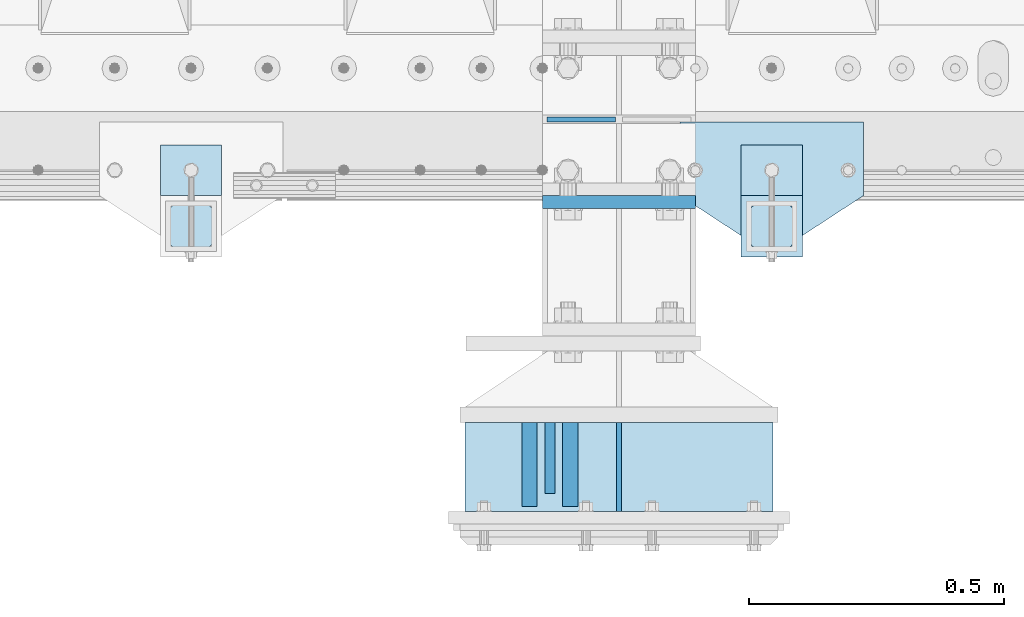
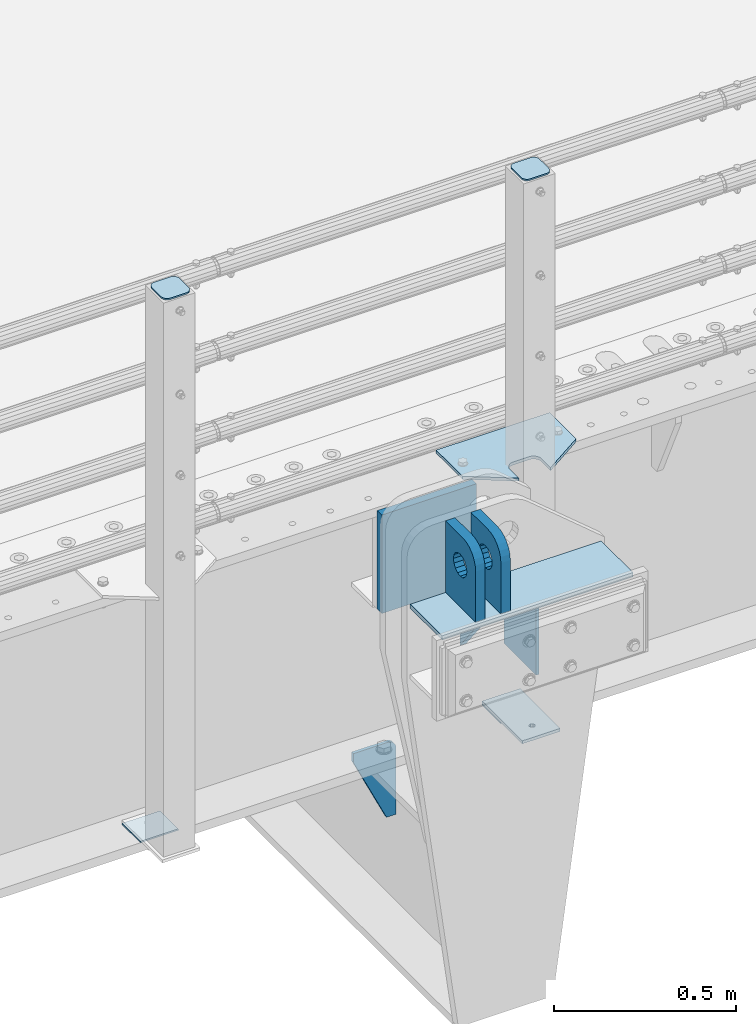
# One storey, part 198 of 240: 13 plates.
"""IFC2X3 building model written with IfcOpenShell, lengths in millimetres."""

import ifcopenshell
import ifcopenshell.guid

model = None  # the IFC model being written
_history = None  # IfcOwnerHistory: only IFC2X3 demands one
_inside = {}  # id of a spatial element -> (the spatial element, [elements in it])
_under = {}  # id of a project, library or spatial element -> (it, [spatial elements below it])
_declared = {}  # id of a project -> (the project, [libraries it declares])
_typed = {}  # id of a type object -> (the type object, [elements of that type])
_made_of = {}  # id of a material, layer set ... -> (it, [elements and type objects made of it])


def new_model(schema):
    """Start an empty IFC model of exactly this schema.

    Asked for "IFC4X3", IfcOpenShell would pick the latest addendum, in which some entities
    have other attributes; the version numbers below select the first issue.
    IFC2X3 requires an IfcOwnerHistory on every rooted entity: one is made here for all.
    """
    global model, _history
    if schema == "IFC4X3":
        model = ifcopenshell.file(schema_version=(4, 3, 0, 0))
    else:
        model = ifcopenshell.file(schema=schema)
    _inside.clear()
    _under.clear()
    _declared.clear()
    _typed.clear()
    _made_of.clear()
    _history = None
    if model.schema == "IFC2X3":
        org = make("IfcOrganization", Name="unknown")
        user = make(
            "IfcPersonAndOrganization",
            ThePerson=make("IfcPerson", FamilyName="unknown"),
            TheOrganization=org,
        )
        app = make(
            "IfcApplication",
            ApplicationDeveloper=org,
            Version="unknown",
            ApplicationFullName="unknown",
            ApplicationIdentifier="unknown",
        )
        _history = make(
            "IfcOwnerHistory",
            OwningUser=user,
            OwningApplication=app,
            ChangeAction="ADDED",
            CreationDate=0,
        )
    return model


def make(cls, **values):
    """One entity of the class cls with the attributes given. An attribute that is None is left unset."""
    return model.create_entity(
        cls, **{name: value for name, value in values.items() if value is not None}
    )


def rooted(cls, **values):
    """An entity with a GlobalId (a new one), such as an element, a storey or a relation."""
    return make(cls, GlobalId=ifcopenshell.guid.new(), OwnerHistory=_history, **values)


def si_unit(unit_type, name, prefix=None):
    """IfcSIUnit, for example si_unit("LENGTHUNIT", "METRE", prefix="MILLI")."""
    return make("IfcSIUnit", UnitType=unit_type, Prefix=prefix, Name=name)


def assignment(units):
    """IfcUnitAssignment: the units of a project."""
    return None if units is None else make("IfcUnitAssignment", Units=units)


def point(xyz):
    """IfcCartesianPoint."""
    return None if xyz is None else make("IfcCartesianPoint", Coordinates=xyz)


def direction(xyz):
    """IfcDirection."""
    return None if xyz is None else make("IfcDirection", DirectionRatios=xyz)


def frame(location, z_axis=None, x_axis=None):
    """IfcAxis2Placement3D, a coordinate frame: its origin and axes. An axis left out is left unset."""
    return make(
        "IfcAxis2Placement3D",
        Location=point(location),
        Axis=direction(z_axis),
        RefDirection=direction(x_axis),
    )


def origin_with_axes():
    """The frame at (0, 0, 0) with the z axis (0, 0, 1) and the x axis (1, 0, 0) written out."""
    return frame((0.0, 0.0, 0.0), z_axis=(0.0, 0.0, 1.0), x_axis=(1.0, 0.0, 0.0))


def place(relative_to, where):
    """IfcLocalPlacement: puts the frame where relative to a parent placement (None: the world)."""
    return make(
        "IfcLocalPlacement", PlacementRelTo=relative_to, RelativePlacement=where
    )


def context(
    kind, dimensions, precision=None, world=None, true_north=None, identifier=None
):
    """IfcGeometricRepresentationContext, for example the 3D "Model" context."""
    return make(
        "IfcGeometricRepresentationContext",
        ContextIdentifier=identifier,
        ContextType=kind,
        CoordinateSpaceDimension=dimensions,
        Precision=precision,
        WorldCoordinateSystem=world,
        TrueNorth=true_north,
    )


def subcontext(parent, identifier, kind, view, scale=None):
    """IfcGeometricRepresentationSubContext, for example "Body" below "Model"."""
    return make(
        "IfcGeometricRepresentationSubContext",
        ContextIdentifier=identifier,
        ContextType=kind,
        ParentContext=parent,
        TargetScale=scale,
        TargetView=view,
    )


def project(units=None, contexts=None):
    """IfcProject with its units and contexts."""
    return rooted(
        "IfcProject",
        Name="project",
        RepresentationContexts=contexts,
        UnitsInContext=assignment(units),
    )


def spatial(cls, under=None, at=None, **own):
    """A site, building, storey or space (cls), placed at a placement, below another one or the project."""
    s = rooted(cls, ObjectPlacement=at, **own)
    if under is not None:
        _under.setdefault(under.id(), (under, []))[1].append(s)
    return s


def faces_of(points, faces, orient=None, outer=None):
    """IfcFace entities. A face is a list of loops; a loop is a list of indices into points, from 0.

    orient and outer hold one flag for each loop. By default every Orientation is true, the
    first loop of a face is its IfcFaceOuterBound and the others are IfcFaceBound.
    """
    made = []
    for i, loops in enumerate(faces):
        bounds = []
        for j, loop in enumerate(loops):
            is_outer = j == 0 if outer is None else outer[i][j]
            bounds.append(
                make(
                    "IfcFaceOuterBound" if is_outer else "IfcFaceBound",
                    Bound=make("IfcPolyLoop", Polygon=[points[k] for k in loop]),
                    Orientation=True if orient is None else orient[i][j],
                )
            )
        made.append(make("IfcFace", Bounds=bounds))
    return made


def faceted_brep(points, faces, orient=None, outer=None, voids=None):
    """IfcFacetedBrep: a solid bounded by flat faces; with voids (closed shells), ...WithVoids."""
    shared = [point(p) for p in points]
    hull = make("IfcClosedShell", CfsFaces=faces_of(shared, faces, orient, outer))
    if voids is None:
        return make("IfcFacetedBrep", Outer=hull)
    return make(
        "IfcFacetedBrepWithVoids",
        Outer=hull,
        Voids=[
            make(cls, CfsFaces=faces_of(shared, fs, o, b)) for cls, fs, o, b in voids
        ],
    )


def shape(context_of_items, identifier, shape_type, items):
    """IfcShapeRepresentation: the items that make up one representation, for example the "Body"."""
    return make(
        "IfcShapeRepresentation",
        ContextOfItems=context_of_items,
        RepresentationIdentifier=identifier,
        RepresentationType=shape_type,
        Items=items,
    )


def material(Name=None, Category=None):
    """IfcMaterial."""
    return make("IfcMaterial", Name=Name, Category=Category)


def made_of(thing, what):
    """Note that an element or type object is made of a material, layer set ...; save() writes the relation."""
    if what is not None:
        _made_of.setdefault(what.id(), (what, []))[1].append(thing)
    return thing


def type_object(cls, material=None, **own):
    """A type object (cls), such as IfcWallType, which elements share."""
    return made_of(rooted(cls, **own), material)


def element(
    cls,
    number,
    at=None,
    inside=None,
    cuts=None,
    type_object=None,
    material=None,
    context=None,
    identifier="Body",
    shape_type=None,
    held_by="IfcProductDefinitionShape",
    body=None,
    shapes=None,
    **own,
):
    """One element of the class cls, such as IfcWall. Its Tag is "e" and its number.

    at: its placement. inside: the storey or other place that contains it. cuts: it is an
    opening in that element (IfcRelVoidsElement). A single representation is given by context,
    identifier, shape_type and body (its items); several are given by shapes. held_by: the class
    of the entity that holds the representations. save() writes the other relations.
    """
    e = rooted(cls, Tag="e%d" % number, ObjectPlacement=at, **own)
    if body is not None:
        shapes = [shape(context, identifier, shape_type, body)]
    if shapes is not None:
        e.Representation = make(held_by, Representations=shapes)
    if inside is not None:
        _inside.setdefault(inside.id(), (inside, []))[1].append(e)
    if cuts is not None:
        rooted(
            "IfcRelVoidsElement", RelatingBuildingElement=cuts, RelatedOpeningElement=e
        )
    if type_object is not None:
        _typed.setdefault(type_object.id(), (type_object, []))[1].append(e)
    return made_of(e, material)


def aggregate(whole, parts):
    """IfcRelAggregates: a whole, such as a stair, and the parts it consists of."""
    return rooted("IfcRelAggregates", RelatingObject=whole, RelatedObjects=parts)


def save(model, path):
    """Write the relations noted so far, then the file.

    IfcRelAggregates (storeys below a building ...), IfcRelContainedInSpatialStructure (elements
    in a storey), IfcRelDefinesByType, IfcRelAssociatesMaterial and IfcRelDeclares: one each for
    every whole, place, type object, material and project.
    """
    for whole, parts in _under.values():
        aggregate(whole, parts)
    for where, things in _inside.values():
        rooted(
            "IfcRelContainedInSpatialStructure",
            RelatedElements=things,
            RelatingStructure=where,
        )
    for kind, things in _typed.values():
        rooted("IfcRelDefinesByType", RelatedObjects=things, RelatingType=kind)
    for what, things in _made_of.values():
        rooted("IfcRelAssociatesMaterial", RelatedObjects=things, RelatingMaterial=what)
    for by, libraries in _declared.values():
        rooted("IfcRelDeclares", RelatingContext=by, RelatedDefinitions=libraries)
    model.write(path)


model = new_model("IFC2X3")

# Units and contexts
model_context = context("Model", 3, precision=1e-05, world=origin_with_axes())
body_context = subcontext(model_context, "Body", "Model", "MODEL_VIEW")
ifc_project = project(units=[si_unit("LENGTHUNIT", "METRE", prefix="MILLI"), si_unit("AREAUNIT", "SQUARE_METRE"), si_unit("VOLUMEUNIT", "CUBIC_METRE"), si_unit("MASSUNIT", "GRAM", prefix="KILO"), si_unit("TIMEUNIT", "SECOND"), si_unit("PLANEANGLEUNIT", "RADIAN"), si_unit("SOLIDANGLEUNIT", "STERADIAN"), si_unit("THERMODYNAMICTEMPERATUREUNIT", "DEGREE_CELSIUS"), si_unit("LUMINOUSINTENSITYUNIT", "LUMEN")], contexts=[model_context])

# Site, building, storey
site_placement = place(None, origin_with_axes())
site = spatial("IfcSite", under=ifc_project, at=site_placement, CompositionType="ELEMENT")
building_placement = place(site_placement, origin_with_axes())
building = spatial("IfcBuilding", under=site, at=building_placement, Name="Standard", CompositionType="ELEMENT")
storey_placement = place(building_placement, origin_with_axes())
storey = spatial("IfcBuildingStorey", under=building, at=storey_placement, Name="Undefined", CompositionType="ELEMENT", Elevation=0.0)

# Plates
ifc_material_1 = material(Name="STEEL/S355N")
plate_type_1 = type_object("IfcPlateType", PredefinedType="NOTDEFINED")
plate_1_placement = place(storey_placement, frame((52704.5000000536, 23264.9999999666, -14.000018238301), z_axis=(0.0, 0.0, -1.0), x_axis=(0.0, 1.0, 0.0)))
element("IfcPlate", 1, at=plate_1_placement, inside=storey, type_object=plate_type_1, material=ifc_material_1, context=body_context, shape_type="Brep", body=[
    faceted_brep([(0.0, -10.0, 0.0), (140.0, -10.0, 180.0), (140.0, 10.0, 180.0), (0.0, 10.0, 0.0), (140.0, -10.0, -1.81898940354586e-12), (140.0, 10.0, -1.81898940354586e-12)], [[[0, 1, 2, 3]], [[1, 4, 5, 2]], [[4, 0, 3, 5]], [[5, 3, 2]], [[4, 1, 0]]]),
])
plate_type_2 = type_object("IfcPlateType", PredefinedType="NOTDEFINED")
plate_2_placement = place(storey_placement, frame((52744.5000000519, 23404.9999999666, -1.8238333723275e-05), z_axis=(0.0, -1.0, 0.0), x_axis=(0.0, 0.0, 1.0)))
element("IfcPlate", 2, at=plate_2_placement, inside=storey, type_object=plate_type_2, material=ifc_material_1, context=body_context, shape_type="Brep", body=[
    faceted_brep([(113.837049096081, 14.9999999525899, 53.8370489460576), (113.837049096081, -15.0000000474101, 53.8370492460599), (125.840713002475, -15.0000001276203, 45.8164574470502), (125.840713002475, 14.9999998723797, 45.8164571470479), (105.816457297066, 15.0000000726213, 65.8407128524559), (105.816457297066, -14.9999999273787, 65.8407131524582), (102.999999999984, 15.0000002142187, 79.9999998499625), (102.999999999984, -14.9999997857813, 80.0000001499648), (105.816457297066, 15.0000003558089, 94.159286847469), (105.816457297066, -14.9999996441911, 94.1592871474713), (113.837049096081, 15.0000004758476, 106.162950753867), (113.837049096081, -14.9999995241524, 106.16295105387), (125.840713002475, 15.0000005560505, 114.183542552877), (125.840713002475, -14.9999994439495, 114.183542852879), (139.999999999984, 15.0000005842085, 116.999999849962), (139.999999999984, -14.9999994157915, 117.000000149965), (154.159286997492, 15.0000005560505, 114.183542552877), (154.159286997492, -14.9999994439495, 114.183542852879), (166.162950903886, 15.0000004758476, 106.162950753867), (166.162950903886, -14.9999995241524, 106.16295105387), (174.183542702901, 15.0000003558089, 94.159286847469), (174.183542702901, -14.9999996441911, 94.1592871474713), (176.999999999984, 15.0000002142187, 79.9999998499625), (176.999999999984, -14.9999997857813, 80.0000001499648), (174.183542702901, 15.0000000726213, 65.8407128524559), (174.183542702901, -14.9999999273787, 65.8407131524582), (166.162950903886, 14.9999999525899, 53.8370489460576), (166.162950903886, -15.0000000474101, 53.8370492460599), (154.159286997492, 14.9999998723797, 45.8164571470479), (154.159286997492, -15.0000001276203, 45.8164574470502), (139.999999999984, 14.9999998442217, 42.9999998499625), (139.999999999984, -15.0000001557783, 43.0000001499648), (240.000015258789, -14.9999999999927, -2.03726813197136e-10), (240.001666876698, -15.0, 94.9959403776302), (237.616787699976, -14.9999999999927, 113.113322498939), (230.624045898169, -14.9999999999927, 129.996116868075), (219.499985670386, -14.9999999999927, 144.493787979867), (205.002693976271, -14.9999999999927, 155.618342674454), (188.120138118986, -14.9999999999927, 162.611660295071), (170.002837349484, -14.9999999999927, 164.997157401471), (-1.40620068123098e-06, -14.9999999999927, 165.000000000007), (0.0, -15.0, 0.0), (0.0, 15.0, 0.0), (240.000015258789, 15.0000000000073, -2.03726813197136e-10), (240.001666876698, 15.0, 94.9959403776229), (237.616787699976, 15.0000000000073, 113.113322498939), (230.624045898169, 15.0000000000073, 129.996116868067), (219.499985670386, 15.0000000000073, 144.493787979867), (205.002693976271, 15.0000000000073, 155.618342674454), (188.120138118986, 15.0000000000073, 162.611660295064), (170.002837349484, 15.0000000000073, 164.997157401463), (-1.40620068123098e-06, 15.0000000000073, 165.0)], [[[0, 1, 2, 3]], [[4, 5, 1, 0]], [[6, 7, 5, 4]], [[8, 9, 7, 6]], [[10, 11, 9, 8]], [[12, 13, 11, 10]], [[14, 15, 13, 12]], [[16, 17, 15, 14]], [[18, 19, 17, 16]], [[20, 21, 19, 18]], [[22, 23, 21, 20]], [[24, 25, 23, 22]], [[26, 27, 25, 24]], [[28, 29, 27, 26]], [[30, 31, 29, 28]], [[3, 2, 31, 30]], [[32, 33, 34, 35, 36, 37, 38, 39, 40, 41], [19, 21, 23, 25, 27, 29, 31, 2, 1, 5, 7, 9, 11, 13, 15, 17]], [[32, 41, 42, 43]], [[33, 32, 43, 44]], [[34, 33, 44, 45]], [[35, 34, 45, 46]], [[36, 35, 46, 47]], [[37, 36, 47, 48]], [[38, 37, 48, 49]], [[39, 38, 49, 50]], [[40, 39, 50, 51]], [[41, 40, 51, 42]], [[50, 49, 48, 47, 46, 45, 44, 43, 42, 51], [10, 8, 6, 4, 0, 3, 30, 28, 26, 24, 22, 20, 18, 16, 14, 12]]]),
])
plate_3_placement = place(storey_placement, frame((52664.5000000536, 23404.9999999666, -1.8238333723275e-05), z_axis=(0.0, -1.0, 0.0), x_axis=(0.0, 0.0, 1.0)))
element("IfcPlate", 3, at=plate_3_placement, inside=storey, type_object=plate_type_2, material=ifc_material_1, context=body_context, shape_type="Brep", body=[
    faceted_brep([(113.837049096081, 14.9999999525899, 53.8370489460576), (113.837049096081, -15.0000000474101, 53.8370492460599), (125.840713002475, -15.0000001276203, 45.8164574470502), (125.840713002475, 14.9999998723797, 45.8164571470479), (105.816457297066, 15.0000000726213, 65.8407128524559), (105.816457297066, -14.9999999273787, 65.8407131524582), (102.999999999984, 15.0000002142187, 79.9999998499625), (102.999999999984, -14.9999997857813, 80.0000001499648), (105.816457297066, 15.0000003558089, 94.159286847469), (105.816457297066, -14.9999996441911, 94.1592871474713), (113.837049096081, 15.0000004758476, 106.162950753867), (113.837049096081, -14.9999995241524, 106.16295105387), (125.840713002475, 15.0000005560505, 114.183542552877), (125.840713002475, -14.9999994439495, 114.183542852879), (139.999999999984, 15.0000005842085, 116.999999849962), (139.999999999984, -14.9999994157915, 117.000000149965), (154.159286997492, 15.0000005560505, 114.183542552877), (154.159286997492, -14.9999994439495, 114.183542852879), (166.162950903886, 15.0000004758476, 106.162950753867), (166.162950903886, -14.9999995241524, 106.16295105387), (174.183542702901, 15.0000003558089, 94.159286847469), (174.183542702901, -14.9999996441911, 94.1592871474713), (176.999999999984, 15.0000002142187, 79.9999998499625), (176.999999999984, -14.9999997857813, 80.0000001499648), (174.183542702901, 15.0000000726213, 65.8407128524559), (174.183542702901, -14.9999999273787, 65.8407131524582), (166.162950903886, 14.9999999525899, 53.8370489460576), (166.162950903886, -15.0000000474101, 53.8370492460599), (154.159286997492, 14.9999998723797, 45.8164571470479), (154.159286997492, -15.0000001276203, 45.8164574470502), (139.999999999984, 14.9999998442217, 42.9999998499625), (139.999999999984, -15.0000001557783, 43.0000001499648), (240.000015258789, -14.9999999999927, -2.03726813197136e-10), (240.0, -14.9999999999927, 95.0), (237.614807840235, -14.9999999999927, 113.117333157177), (230.621778264911, -14.9999999999927, 130.0), (219.497474683058, -14.9999999999927, 144.497474683056), (205.0, -14.9999999999927, 155.621778264911), (188.117333157176, -14.9999999999927, 162.614807840233), (170.0, -14.9999999999927, 165.0), (-1.40620068123098e-06, -14.9999999999927, 165.000000000007), (0.0, -15.0, 0.0), (0.0, 15.0, 0.0), (240.000015258789, 15.0000000000073, -2.03726813197136e-10), (240.0, 15.0000000000073, 95.0), (237.614807840235, 15.0000000000073, 113.117333157177), (230.621778264911, 15.0000000000073, 130.0), (219.497474683058, 15.0000000000073, 144.497474683063), (205.0, 15.0000000000073, 155.621778264911), (188.117333157176, 15.0000000000073, 162.614807840233), (170.0, 15.0000000000073, 165.0), (-1.40620068123098e-06, 15.0000000000073, 165.0)], [[[0, 1, 2, 3]], [[4, 5, 1, 0]], [[6, 7, 5, 4]], [[8, 9, 7, 6]], [[10, 11, 9, 8]], [[12, 13, 11, 10]], [[14, 15, 13, 12]], [[16, 17, 15, 14]], [[18, 19, 17, 16]], [[20, 21, 19, 18]], [[22, 23, 21, 20]], [[24, 25, 23, 22]], [[26, 27, 25, 24]], [[28, 29, 27, 26]], [[30, 31, 29, 28]], [[3, 2, 31, 30]], [[32, 33, 34, 35, 36, 37, 38, 39, 40, 41], [19, 21, 23, 25, 27, 29, 31, 2, 1, 5, 7, 9, 11, 13, 15, 17]], [[32, 41, 42, 43]], [[33, 32, 43, 44]], [[34, 33, 44, 45]], [[35, 34, 45, 46]], [[36, 35, 46, 47]], [[37, 36, 47, 48]], [[38, 37, 48, 49]], [[39, 38, 49, 50]], [[40, 39, 50, 51]], [[41, 40, 51, 42]], [[50, 49, 48, 47, 46, 45, 44, 43, 42, 51], [10, 8, 6, 4, 0, 3, 30, 28, 26, 24, 22, 20, 18, 16, 14, 12]]]),
])
plate_type_3 = type_object("IfcPlateType", PredefinedType="NOTDEFINED")
plate_4_placement = place(storey_placement, frame((52690.0, 23837.5000000345, -340.000018222276), z_axis=(0.0, 0.0, 1.0), x_axis=(1.0, 0.0, 0.0)))
element("IfcPlate", 4, at=plate_4_placement, inside=storey, type_object=plate_type_3, material=ifc_material_1, context=body_context, shape_type="Brep", body=[
    faceted_brep([(0.0, -12.5, 0.0), (0.0, -12.5, 330.0), (0.0, 12.5, 330.0), (0.0, 12.5, 0.0), (300.0, -12.5, 330.0), (300.0, 12.5, 330.0), (300.0, -12.5, 0.0), (300.0, 12.5, 0.0)], [[[0, 1, 2, 3]], [[1, 4, 5, 2]], [[4, 6, 7, 5]], [[6, 0, 3, 7]], [[5, 7, 3, 2]], [[6, 4, 1, 0]]]),
])
plate_type_4 = type_object("IfcPlateType", PredefinedType="NOTDEFINED")
plate_5_placement = place(storey_placement, frame((52833.4999999998, 24000.0000000345, -915.000018222274), z_axis=(0.0, 0.0, -1.0), x_axis=(-1.0, 0.0, 0.0)))
element("IfcPlate", 5, at=plate_5_placement, inside=storey, type_object=plate_type_4, material=ifc_material_1, context=body_context, shape_type="Brep", body=[
    faceted_brep([(0.0, -5.0, 27.0), (0.0, -5.0, 250.0), (0.0, 5.0, 250.0), (0.0, 5.0, 27.0), (30.0, -5.0, 250.0), (30.0, 5.0, 250.0), (135.0, -5.0, 30.0), (135.0, 5.0, 30.0), (135.0, -5.0, 0.0), (135.0, 5.0, 0.0), (27.0, -5.0, 0.0), (27.0, 5.0, 0.0), (22.311499202995, -5.0, 0.410190668670339), (22.311499202995, 5.0, 0.410190668670339), (17.7654561302043, -5.0, 1.62829923878053), (17.7654561302043, 5.0, 1.62829923878053), (13.5, -5.0, 3.6173140978201), (13.5, 5.0, 3.6173140978201), (9.64473453846585, -5.0, 6.31680003578754), (9.64473453846585, 5.0, 6.31680003578754), (6.31680003579095, -5.0, 9.64473453846347), (6.31680003579095, 5.0, 9.64473453846347), (3.61731409782078, -5.0, 13.5), (3.61731409782078, 5.0, 13.5), (1.62829923877871, -5.0, 17.765456130207), (1.62829923877871, 5.0, 17.765456130207), (0.410190668670111, -5.0, 22.3114992029929), (0.410190668670111, 5.0, 22.3114992029929)], [[[0, 1, 2, 3]], [[1, 4, 5, 2]], [[4, 6, 7, 5]], [[6, 8, 9, 7]], [[8, 10, 11, 9]], [[10, 12, 13, 11]], [[12, 14, 15, 13]], [[14, 16, 17, 15]], [[16, 18, 19, 17]], [[18, 20, 21, 19]], [[20, 22, 23, 21]], [[22, 24, 25, 23]], [[24, 26, 27, 25]], [[26, 0, 3, 27]], [[5, 7, 9, 11, 13, 15, 17, 19, 21, 23, 25, 27, 3, 2]], [[26, 24, 22, 20, 18, 16, 14, 12, 10, 8, 6, 4, 1, 0]]]),
])
ifc_material_2 = material(Name="STEEL/S355J2")
plate_type_5 = type_object("IfcPlateType", PredefinedType="NOTDEFINED")
plate_6_placement = place(storey_placement, frame((53320.0, 23995.0, 5.00000000004911), z_axis=(0.0, -1.0, 0.0), x_axis=(-1.0, 0.0, 0.0)))
element("IfcPlate", 6, at=plate_6_placement, inside=storey, type_object=plate_type_5, material=ifc_material_2, context=body_context, shape_type="Brep", body=[
    faceted_brep([(0.0, -5.0, 0.0), (2.31396552408114e-06, -5.0, 145.0), (2.31396552408114e-06, 5.0, 145.0), (0.0, 5.0, 0.0), (130.0, -5.0, 230.0), (130.0, 5.0, 230.0), (130.0, -5.0, 180.0), (130.0, 5.0, 180.0), (130.48036798992, -5.0, 175.122741949599), (130.48036798992, 5.0, 175.122741949599), (131.903011687216, -5.0, 170.432914190875), (131.903011687216, 5.0, 170.432914190875), (134.213259692435, -5.0, 166.110744174512), (134.213259692435, 5.0, 166.110744174512), (137.322330470335, -5.0, 162.322330470335), (137.322330470335, 5.0, 162.322330470335), (141.110744174512, -5.0, 159.213259692435), (141.110744174512, 5.0, 159.213259692435), (145.432914190875, -5.0, 156.903011687216), (145.432914190875, 5.0, 156.903011687216), (150.122741949599, -5.0, 155.48036798992), (150.122741949599, 5.0, 155.48036798992), (155.0, -5.0, 155.0), (155.0, 5.0, 155.0), (205.0, -5.0, 155.0), (205.0, 5.0, 155.0), (209.877258050401, -5.0, 155.48036798992), (209.877258050401, 5.0, 155.48036798992), (214.567085809125, -5.0, 156.903011687216), (214.567085809125, 5.0, 156.903011687216), (218.889255825488, -5.0, 159.213259692435), (218.889255825488, 5.0, 159.213259692435), (222.677669529665, -5.0, 162.322330470335), (222.677669529665, 5.0, 162.322330470335), (225.786740307565, -5.0, 166.110744174512), (225.786740307565, 5.0, 166.110744174512), (228.096988312784, -5.0, 170.432914190875), (228.096988312784, 5.0, 170.432914190875), (229.51963201008, -5.0, 175.122741949599), (229.51963201008, 5.0, 175.122741949599), (230.0, -5.0, 180.0), (230.0, 5.0, 180.0), (230.0, -5.0, 230.0), (230.0, 5.0, 230.0), (360.0, -5.0, 145.0), (360.0, 5.0, 145.0), (360.0, -5.0, -7.27595761418343e-12), (360.0, 5.0, -7.27595761418343e-12)], [[[0, 1, 2, 3]], [[1, 4, 5, 2]], [[4, 6, 7, 5]], [[6, 8, 9, 7]], [[8, 10, 11, 9]], [[10, 12, 13, 11]], [[12, 14, 15, 13]], [[14, 16, 17, 15]], [[16, 18, 19, 17]], [[18, 20, 21, 19]], [[20, 22, 23, 21]], [[22, 24, 25, 23]], [[24, 26, 27, 25]], [[26, 28, 29, 27]], [[28, 30, 31, 29]], [[30, 32, 33, 31]], [[32, 34, 35, 33]], [[34, 36, 37, 35]], [[36, 38, 39, 37]], [[38, 40, 41, 39]], [[40, 42, 43, 41]], [[42, 44, 45, 43]], [[44, 46, 47, 45]], [[46, 0, 3, 47]], [[5, 7, 9, 11, 13, 15, 17, 19, 21, 23, 25, 27, 29, 31, 33, 35, 37, 39, 41, 43, 45, 47, 3, 2]], [[46, 44, 42, 40, 38, 36, 34, 32, 30, 28, 26, 24, 22, 20, 18, 16, 14, 12, 10, 8, 6, 4, 1, 0]]]),
])
plate_type_6 = type_object("IfcPlateType", PredefinedType="NOTDEFINED")
plate_7_placement = place(storey_placement, frame((53199.9999999999, 23949.9999999998, -850.000000000002), z_axis=(0.0, -1.0, 0.0), x_axis=(-1.0, 0.0, 0.0)))
element("IfcPlate", 7, at=plate_7_placement, inside=storey, type_object=plate_type_6, material=ifc_material_2, context=body_context, shape_type="Brep", body=[
    faceted_brep([(53.6360389691836, -5.0, 176.363961030467), (53.6360389691836, 5.0, 176.363961030467), (59.9999999998618, 5.0, 178.999999999789), (59.9999999998618, -5.0, 178.999999999789), (66.3639610305399, 5.0, 176.363961030467), (66.3639610305399, -5.0, 176.363961030467), (68.9999999998618, 5.0, 169.999999999789), (68.9999999998618, -5.0, 169.999999999789), (66.3639610305399, 5.0, 163.636038969111), (66.3639610305399, -5.0, 163.636038969111), (59.9999999998618, 5.0, 160.999999999789), (59.9999999998618, -5.0, 160.999999999789), (53.6360389691836, 5.0, 163.636038969111), (53.6360389691836, -5.0, 163.636038969111), (50.9999999998618, 5.0, 169.999999999789), (50.9999999998618, -5.0, 169.999999999789), (120.0, -5.0, 0.0), (120.0, -5.0, 220.0), (0.0, -5.0, 220.0), (0.0, -5.0, 0.0), (0.0, 5.0, 0.0), (120.0, 5.0, 0.0), (120.0, 5.0, 220.0), (0.0, 5.0, 220.0)], [[[0, 1, 2, 3]], [[3, 2, 4, 5]], [[5, 4, 6, 7]], [[7, 6, 8, 9]], [[9, 8, 10, 11]], [[11, 10, 12, 13]], [[13, 12, 14, 15]], [[15, 14, 1, 0]], [[16, 17, 18, 19], [11, 13, 15, 0, 3, 5, 7, 9]], [[16, 19, 20, 21]], [[17, 16, 21, 22]], [[18, 17, 22, 23]], [[19, 18, 23, 20]], [[22, 21, 20, 23], [2, 1, 14, 12, 10, 8, 6, 4]]]),
])
plate_type_7 = type_object("IfcPlateType", PredefinedType="NOTDEFINED")
plate_8_placement = place(storey_placement, frame((53095.9999999999, 23833.9999999998, 1012.50000000001), z_axis=(0.0, -1.0, 0.0), x_axis=(1.0, 0.0, 0.0)))
element("IfcPlate", 8, at=plate_8_placement, inside=storey, type_object=plate_type_7, material=ifc_material_2, context=body_context, shape_type="Brep", body=[
    faceted_brep([(0.0, -2.5, 19.0), (0.0, -2.5, 69.0), (0.0, 2.5, 69.0), (0.0, 2.5, 19.0), (0.476369668547704, -2.5, 73.2278977451715), (0.476369668547704, 2.5, 73.2278977451715), (1.88159150985302, -2.5, 77.2437910432345), (1.88159150985302, 2.5, 77.2437910432345), (4.14520183311106, -2.5, 80.8463062353185), (4.14520183311106, 2.5, 80.8463062353185), (7.15369376468152, -2.5, 83.8547981668889), (7.15369376468152, 2.5, 83.8547981668889), (10.7562089567655, -2.5, 86.118408490147), (10.7562089567655, 2.5, 86.118408490147), (14.7721022548285, -2.5, 87.5236303314523), (14.7721022548285, 2.5, 87.5236303314523), (19.0, -2.5, 88.0), (19.0, 2.5, 88.0), (69.0, -2.5, 88.0), (69.0, 2.5, 88.0), (73.2278977451715, -2.5, 87.5236303314523), (73.2278977451715, 2.5, 87.5236303314523), (77.2437910432345, -2.5, 86.118408490147), (77.2437910432345, 2.5, 86.118408490147), (80.8463062353185, -2.5, 83.8547981668889), (80.8463062353185, 2.5, 83.8547981668889), (83.8547981668889, -2.5, 80.8463062353185), (83.8547981668889, 2.5, 80.8463062353185), (86.118408490147, -2.5, 77.2437910432345), (86.118408490147, 2.5, 77.2437910432345), (87.5236303314523, -2.5, 73.2278977451715), (87.5236303314523, 2.5, 73.2278977451715), (88.0, -2.5, 69.0), (88.0, 2.5, 69.0), (88.0, -2.5, 19.0), (88.0, 2.5, 19.0), (87.5236303314523, -2.5, 14.7721022548285), (87.5236303314523, 2.5, 14.7721022548285), (86.118408490147, -2.5, 10.7562089567655), (86.118408490147, 2.5, 10.7562089567655), (83.8547981668889, -2.5, 7.15369376468152), (83.8547981668889, 2.5, 7.15369376468152), (80.8463062353185, -2.5, 4.14520183311106), (80.8463062353185, 2.5, 4.14520183311106), (77.2437910432345, -2.5, 1.88159150985302), (77.2437910432345, 2.5, 1.88159150985302), (73.2278977451715, -2.5, 0.476369668547704), (73.2278977451715, 2.5, 0.476369668547704), (69.0, -2.5, 0.0), (69.0, 2.5, 0.0), (19.0, -2.5, 0.0), (19.0, 2.5, 0.0), (14.7721022548285, -2.5, 0.476369668547704), (14.7721022548285, 2.5, 0.476369668547704), (10.7562089567655, -2.5, 1.88159150985302), (10.7562089567655, 2.5, 1.88159150985302), (7.15369376468152, -2.5, 4.14520183311106), (7.15369376468152, 2.5, 4.14520183311106), (4.14520183311106, -2.5, 7.15369376468152), (4.14520183311106, 2.5, 7.15369376468152), (1.88159150985302, -2.5, 10.7562089567655), (1.88159150985302, 2.5, 10.7562089567655), (0.476369668547704, -2.5, 14.7721022548285), (0.476369668547704, 2.5, 14.7721022548285)], [[[0, 1, 2, 3]], [[1, 4, 5, 2]], [[4, 6, 7, 5]], [[6, 8, 9, 7]], [[8, 10, 11, 9]], [[10, 12, 13, 11]], [[12, 14, 15, 13]], [[14, 16, 17, 15]], [[16, 18, 19, 17]], [[18, 20, 21, 19]], [[20, 22, 23, 21]], [[22, 24, 25, 23]], [[24, 26, 27, 25]], [[26, 28, 29, 27]], [[28, 30, 31, 29]], [[30, 32, 33, 31]], [[32, 34, 35, 33]], [[34, 36, 37, 35]], [[36, 38, 39, 37]], [[38, 40, 41, 39]], [[40, 42, 43, 41]], [[42, 44, 45, 43]], [[44, 46, 47, 45]], [[46, 48, 49, 47]], [[48, 50, 51, 49]], [[50, 52, 53, 51]], [[52, 54, 55, 53]], [[54, 56, 57, 55]], [[56, 58, 59, 57]], [[58, 60, 61, 59]], [[60, 62, 63, 61]], [[62, 0, 3, 63]], [[5, 7, 9, 11, 13, 15, 17, 19, 21, 23, 25, 27, 29, 31, 33, 35, 37, 39, 41, 43, 45, 47, 49, 51, 53, 55, 57, 59, 61, 63, 3, 2]], [[62, 60, 58, 56, 54, 52, 50, 48, 46, 44, 42, 40, 38, 36, 34, 32, 30, 28, 26, 24, 22, 20, 18, 16, 14, 12, 10, 8, 6, 4, 1, 0]]]),
])
plate_9_placement = place(storey_placement, frame((51955.9999999999, 23833.9999999998, 1012.50000000001), z_axis=(0.0, -1.0, 0.0), x_axis=(1.0, 0.0, 0.0)))
element("IfcPlate", 9, at=plate_9_placement, inside=storey, type_object=plate_type_7, material=ifc_material_2, context=body_context, shape_type="Brep", body=[
    faceted_brep([(0.0, -2.5, 19.0), (0.0, -2.5, 69.0), (0.0, 2.5, 69.0), (0.0, 2.5, 19.0), (0.476369668547704, -2.5, 73.2278977451715), (0.476369668547704, 2.5, 73.2278977451715), (1.88159150985302, -2.5, 77.2437910432345), (1.88159150985302, 2.5, 77.2437910432345), (4.14520183311106, -2.5, 80.8463062353185), (4.14520183311106, 2.5, 80.8463062353185), (7.15369376468152, -2.5, 83.8547981668889), (7.15369376468152, 2.5, 83.8547981668889), (10.7562089567655, -2.5, 86.118408490147), (10.7562089567655, 2.5, 86.118408490147), (14.7721022548285, -2.5, 87.5236303314523), (14.7721022548285, 2.5, 87.5236303314523), (19.0, -2.5, 88.0), (19.0, 2.5, 88.0), (69.0, -2.5, 88.0), (69.0, 2.5, 88.0), (73.2278977451715, -2.5, 87.5236303314523), (73.2278977451715, 2.5, 87.5236303314523), (77.2437910432345, -2.5, 86.118408490147), (77.2437910432345, 2.5, 86.118408490147), (80.8463062353185, -2.5, 83.8547981668889), (80.8463062353185, 2.5, 83.8547981668889), (83.8547981668889, -2.5, 80.8463062353185), (83.8547981668889, 2.5, 80.8463062353185), (86.118408490147, -2.5, 77.2437910432345), (86.118408490147, 2.5, 77.2437910432345), (87.5236303314523, -2.5, 73.2278977451715), (87.5236303314523, 2.5, 73.2278977451715), (88.0, -2.5, 69.0), (88.0, 2.5, 69.0), (88.0, -2.5, 19.0), (88.0, 2.5, 19.0), (87.5236303314523, -2.5, 14.7721022548285), (87.5236303314523, 2.5, 14.7721022548285), (86.118408490147, -2.5, 10.7562089567655), (86.118408490147, 2.5, 10.7562089567655), (83.8547981668889, -2.5, 7.15369376468152), (83.8547981668889, 2.5, 7.15369376468152), (80.8463062353185, -2.5, 4.14520183311106), (80.8463062353185, 2.5, 4.14520183311106), (77.2437910432345, -2.5, 1.88159150985302), (77.2437910432345, 2.5, 1.88159150985302), (73.2278977451715, -2.5, 0.476369668547704), (73.2278977451715, 2.5, 0.476369668547704), (69.0, -2.5, 0.0), (69.0, 2.5, 0.0), (19.0, -2.5, 0.0), (19.0, 2.5, 0.0), (14.7721022548285, -2.5, 0.476369668547704), (14.7721022548285, 2.5, 0.476369668547704), (10.7562089567655, -2.5, 1.88159150985302), (10.7562089567655, 2.5, 1.88159150985302), (7.15369376468152, -2.5, 4.14520183311106), (7.15369376468152, 2.5, 4.14520183311106), (4.14520183311106, -2.5, 7.15369376468152), (4.14520183311106, 2.5, 7.15369376468152), (1.88159150985302, -2.5, 10.7562089567655), (1.88159150985302, 2.5, 10.7562089567655), (0.476369668547704, -2.5, 14.7721022548285), (0.476369668547704, 2.5, 14.7721022548285)], [[[0, 1, 2, 3]], [[1, 4, 5, 2]], [[4, 6, 7, 5]], [[6, 8, 9, 7]], [[8, 10, 11, 9]], [[10, 12, 13, 11]], [[12, 14, 15, 13]], [[14, 16, 17, 15]], [[16, 18, 19, 17]], [[18, 20, 21, 19]], [[20, 22, 23, 21]], [[22, 24, 25, 23]], [[24, 26, 27, 25]], [[26, 28, 29, 27]], [[28, 30, 31, 29]], [[30, 32, 33, 31]], [[32, 34, 35, 33]], [[34, 36, 37, 35]], [[36, 38, 39, 37]], [[38, 40, 41, 39]], [[40, 42, 43, 41]], [[42, 44, 45, 43]], [[44, 46, 47, 45]], [[46, 48, 49, 47]], [[48, 50, 51, 49]], [[50, 52, 53, 51]], [[52, 54, 55, 53]], [[54, 56, 57, 55]], [[56, 58, 59, 57]], [[58, 60, 61, 59]], [[60, 62, 63, 61]], [[62, 0, 3, 63]], [[5, 7, 9, 11, 13, 15, 17, 19, 21, 23, 25, 27, 29, 31, 33, 35, 37, 39, 41, 43, 45, 47, 49, 51, 53, 55, 57, 59, 61, 63, 3, 2]], [[62, 60, 58, 56, 54, 52, 50, 48, 46, 44, 42, 40, 38, 36, 34, 32, 30, 28, 26, 24, 22, 20, 18, 16, 14, 12, 10, 8, 6, 4, 1, 0]]]),
])
plate_type_8 = type_object("IfcPlateType", PredefinedType="NOTDEFINED")
for number, where, z_axis, x_axis in (
    (10, (53199.9999999999, 23949.9999999998, -857.500000000002), (0.0, -1.0, 0.0), (-1.0, 0.0, 0.0)),
    (11, (52059.9999999999, 23949.9999999998, -857.500000000002), (0.0, -1.0, 0.0), (-1.0, 0.0, 0.0)),
):
    element("IfcPlate", number, at=place(storey_placement, frame(where, z_axis=z_axis, x_axis=x_axis)), inside=storey, type_object=plate_type_8, material=ifc_material_2, context=body_context, shape_type="Brep", body=[
        faceted_brep([(0.0, -2.5, 0.0), (0.0, -2.5, 100.0), (0.0, 2.5, 100.0), (0.0, 2.5, 0.0), (120.0, -2.5, 100.0), (120.0, 2.5, 100.0), (120.0, -2.5, 0.0), (120.0, 2.5, 0.0)], [[[0, 1, 2, 3]], [[1, 4, 5, 2]], [[4, 6, 7, 5]], [[6, 0, 3, 7]], [[5, 7, 3, 2]], [[6, 4, 1, 0]]]),
    ])
ifc_material_3 = material()
plate_type_9 = type_object("IfcPlateType", PredefinedType="NOTDEFINED")
plate_10_placement = place(storey_placement, frame((53142.5, 23405.0000000345, -7.0000182222758), z_axis=(0.0, -1.0, 0.0), x_axis=(-1.0, 0.0, 0.0)))
element("IfcPlate", 12, at=plate_10_placement, inside=storey, type_object=plate_type_9, material=ifc_material_3, context=body_context, shape_type="Brep", body=[
    faceted_brep([(0.0, -7.0, 0.0), (0.0, -7.0, 175.0), (0.0, 7.0, 175.0), (0.0, 7.0, 0.0), (605.0, -7.0, 175.0), (605.0, 7.0, 175.0), (605.0, -7.0, 0.0), (605.0, 7.0, 0.0)], [[[0, 1, 2, 3]], [[1, 4, 5, 2]], [[4, 6, 7, 5]], [[6, 0, 3, 7]], [[5, 7, 3, 2]], [[6, 4, 1, 0]]]),
])
plate_type_10 = type_object("IfcPlateType", PredefinedType="NOTDEFINED")
plate_11_placement = place(storey_placement, frame((52840.0, 23230.0000000345, -14.0000182222758), z_axis=(0.0, 0.0, -1.0), x_axis=(0.0, 1.0, 0.0)))
element("IfcPlate", 13, at=plate_11_placement, inside=storey, type_object=plate_type_10, material=ifc_material_1, context=body_context, shape_type="Brep", body=[
    faceted_brep([(0.0, -5.0, 0.0), (0.0, -5.0, 222.0), (0.0, 5.0, 222.0), (0.0, 5.0, 0.0), (175.0, -5.0, 222.0), (175.0, 5.0, 222.0), (175.0, -5.0, 0.0), (175.0, 5.0, 0.0)], [[[0, 1, 2, 3]], [[1, 4, 5, 2]], [[4, 6, 7, 5]], [[6, 0, 3, 7]], [[5, 7, 3, 2]], [[6, 4, 1, 0]]]),
])

save(model, "model.ifc")
